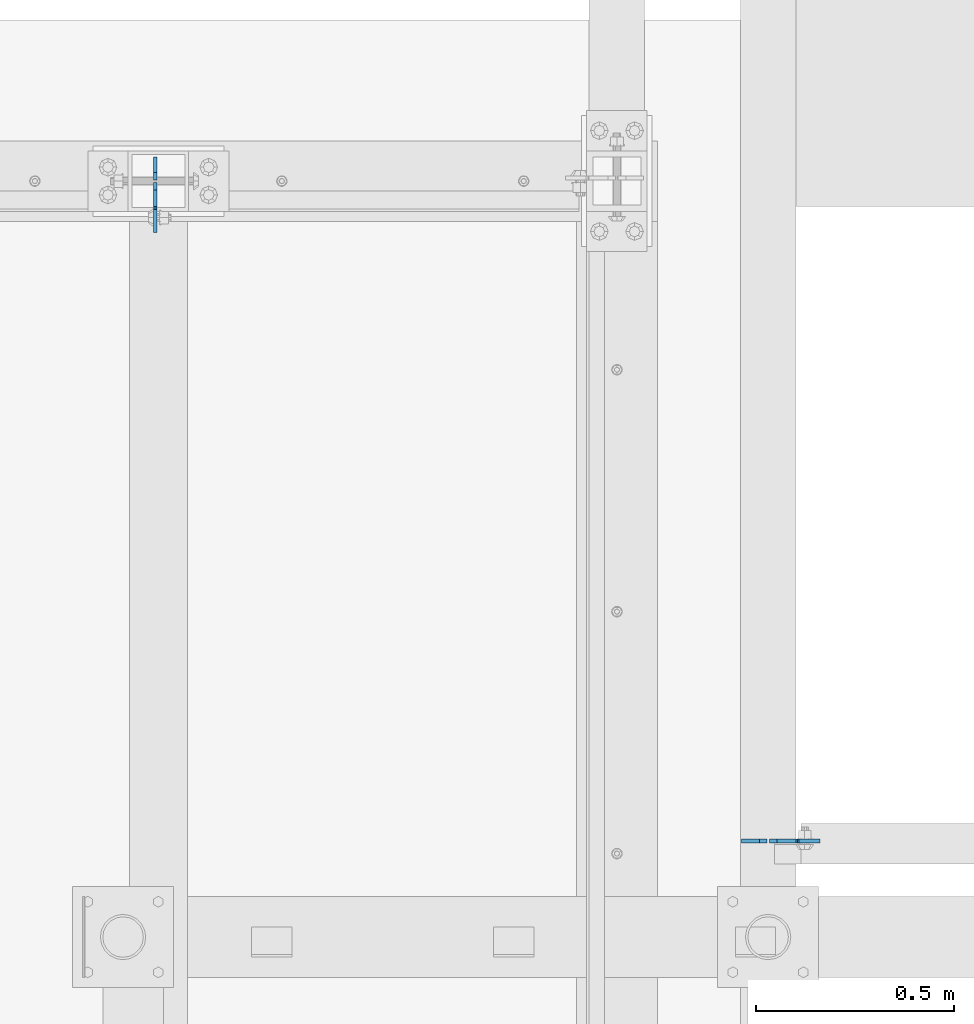
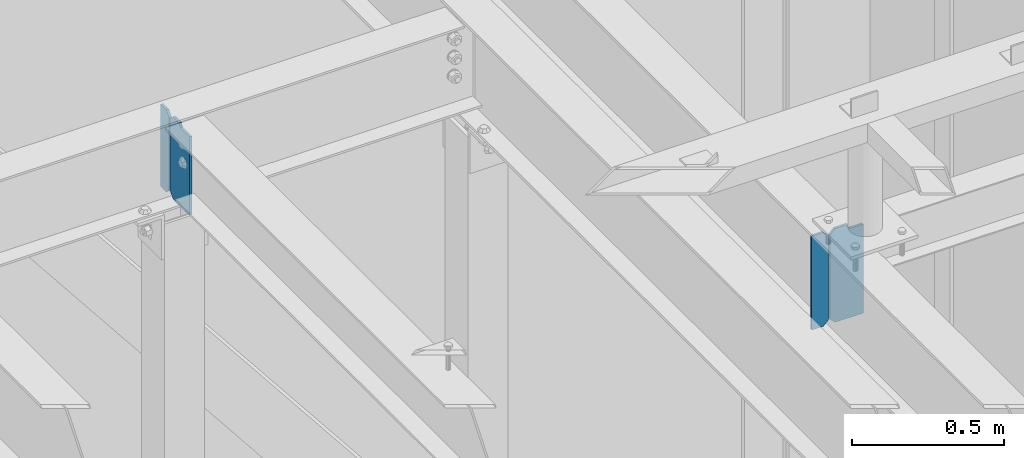
# One storey, part 1083 of 1179: 4 plates, 2 elements without a shape of their own.
"""IFC2X3 building model written with IfcOpenShell, lengths in millimetres."""

from ifc_helpers import new_model, si_unit, frame, origin_with_axes, place, context, subcontext, project, spatial, faceted_brep, material, type_object, element, aggregate, save


model = new_model("IFC2X3")

# Units and contexts
model_context = context("Model", 3, precision=1e-05, world=origin_with_axes())
body_context = subcontext(model_context, "Body", "Model", "MODEL_VIEW")
ifc_project = project(units=[si_unit("LENGTHUNIT", "METRE", prefix="MILLI"), si_unit("AREAUNIT", "SQUARE_METRE"), si_unit("VOLUMEUNIT", "CUBIC_METRE"), si_unit("MASSUNIT", "GRAM", prefix="KILO"), si_unit("TIMEUNIT", "SECOND"), si_unit("PLANEANGLEUNIT", "RADIAN"), si_unit("SOLIDANGLEUNIT", "STERADIAN"), si_unit("THERMODYNAMICTEMPERATUREUNIT", "DEGREE_CELSIUS"), si_unit("LUMINOUSINTENSITYUNIT", "LUMEN")], contexts=[model_context])

# Site, building, storey
site_placement = place(None, origin_with_axes())
site = spatial("IfcSite", under=ifc_project, at=site_placement, CompositionType="ELEMENT")
building_placement = place(site_placement, origin_with_axes())
building = spatial("IfcBuilding", under=site, at=building_placement, Name="Undefined", CompositionType="ELEMENT")
storey_placement = place(building_placement, origin_with_axes())
storey = spatial("IfcBuildingStorey", under=building, at=storey_placement, Name="Undefined", CompositionType="ELEMENT", Elevation=0.0)

# Assembly, plate
assembly_1_placement = place(storey_placement, origin_with_axes())
assembly_1 = element("IfcElementAssembly", 1, at=assembly_1_placement, inside=storey, Name="BEAM", AssemblyPlace="NOTDEFINED", PredefinedType="RIGID_FRAME")
ifc_material = material(Name="STEEL/A36")
plate_type_1 = type_object("IfcPlateType", PredefinedType="NOTDEFINED")
plate_1_placement = place(assembly_1_placement, frame((13022.2618838348, 39430.325, 12779.375), z_axis=(0.0, 0.0, 1.0), x_axis=(0.0, -1.0, 0.0)))
plate_1 = element("IfcPlate", 2, at=plate_1_placement, type_object=plate_type_1, material=ifc_material, Name="PLATE", context=body_context, shape_type="Brep", body=[
    faceted_brep([(60.3250000095268, -4.76250000000073, 330.200000000001), (60.3249999999971, -4.76250000000073, 327.024999809266), (60.3249999999971, 4.76250000000073, 327.024999809266), (60.3250000095268, 4.76250000000073, 330.200000000001), (61.2917299225883, -4.76250000000073, 322.164920291219), (61.2917299225883, 4.76250000000073, 322.164920291219), (64.0447438230622, -4.76250000000073, 318.044743823066), (64.0447438230622, 4.76250000000073, 318.044743823066), (68.1649202912158, -4.76250000000073, 315.291729922588), (68.1649202912158, 4.76250000000073, 315.291729922588), (73.0249998092622, -4.76250000000073, 314.325000000001), (73.0249998092622, 4.76250000000073, 314.325000000001), (127.0, -4.76250000000073, 314.325000000001), (127.0, 4.76250000000073, 314.325000000001), (0.0, -4.76250000000073, 311.150012969971), (19.0499992370605, -4.76250000000073, 330.200012207031), (19.0499992370605, 4.76250000000073, 330.200012207031), (0.0, 4.76250000000073, 311.150012969971), (0.0, -4.76250000000073, 19.0499992370605), (0.0, 4.76250000000073, 19.0499992370605), (19.0499992370605, -4.76250000000073, 0.0), (19.0499992370605, 4.76250000000073, 0.0), (127.0, -4.76250000000073, 0.0), (127.0, 4.76250000000073, 0.0)], [[[0, 1, 2, 3]], [[4, 5, 2, 1]], [[6, 7, 5, 4]], [[8, 9, 7, 6]], [[10, 11, 9, 8]], [[12, 13, 11, 10]], [[14, 15, 16, 17]], [[18, 14, 17, 19]], [[20, 18, 19, 21]], [[22, 20, 21, 23]], [[8, 6, 4, 1, 0, 15, 14, 18, 20, 22, 12, 10]], [[16, 15, 0, 3]], [[23, 21, 19, 17, 16, 3, 2, 5, 7, 9, 11, 13]], [[22, 23, 13, 12]]]),
])

assembly_2_placement = place(storey_placement, origin_with_axes())
assembly_2 = element("IfcElementAssembly", 3, at=assembly_2_placement, inside=storey, Name="BEAM", AssemblyPlace="NOTDEFINED", PredefinedType="RIGID_FRAME")
plate_2_placement = place(assembly_2_placement, frame((14570.075, 37770.5942499161, 12728.575), z_axis=(0.0, 0.0, 1.0), x_axis=(1.0, 0.0, 0.0)))
plate_2 = element("IfcPlate", 4, at=plate_2_placement, type_object=plate_type_1, material=ifc_material, Name="PLATE", context=body_context, shape_type="Brep", body=[
    faceted_brep([(66.6749998164378, -4.76249999999709, 377.825), (66.6749999434469, -4.76249999999709, 371.474999553748), (66.6749999434469, 4.76249999999709, 371.474999553748), (66.6749998164378, 4.76249999999709, 377.825), (67.641729938794, -4.76249999999709, 366.614920114053), (67.641729938794, 4.76249999999709, 366.614920114053), (70.394743855788, -4.76249999999709, 362.494743732281), (70.394743855788, 4.76249999999709, 362.494743732281), (74.5149202922948, -4.76249999999709, 359.741729897201), (74.5149202922948, 4.76249999999709, 359.741729897201), (79.3749997512095, -4.76249999999709, 358.774999998475), (79.3749997512095, 4.76249999999709, 358.774999998475), (127.000000004868, -4.76249999999709, 358.774999992755), (127.0, 4.76249999999709, 358.774999992755), (0.0, -4.76249999999709, 358.775000762939), (19.0499992370605, -4.76249999999709, 377.825), (19.0499992370605, 4.76249999999709, 377.825), (0.0, 4.76249999999709, 358.775000762939), (0.0, -4.76250000000073, 19.0499992370605), (0.0, 4.76250000000073, 19.0499992370605), (19.0499992370605, -4.76250000000073, 0.0), (19.0499992370605, 4.76250000000073, 0.0), (127.0, -4.76250000000073, 0.0), (127.0, 4.76250000000073, 0.0)], [[[0, 1, 2, 3]], [[4, 5, 2, 1]], [[6, 7, 5, 4]], [[8, 9, 7, 6]], [[10, 11, 9, 8]], [[12, 13, 11, 10]], [[14, 15, 16, 17]], [[18, 14, 17, 19]], [[20, 18, 19, 21]], [[22, 20, 21, 23]], [[8, 6, 4, 1, 0, 15, 14, 18, 20, 22, 12, 10]], [[16, 15, 0, 3]], [[23, 21, 19, 17, 16, 3, 2, 5, 7, 9, 11, 13]], [[22, 23, 13, 12]]]),
])

# Plate
plate_type_2 = type_object("IfcPlateType", PredefinedType="NOTDEFINED")
plate_3_placement = place(assembly_1_placement, frame((13022.2618838348, 39436.675, 12779.375), z_axis=(0.0, 0.0, 1.0), x_axis=(0.0, 1.0, 0.0)))
plate_3 = element("IfcPlate", 5, at=plate_3_placement, type_object=plate_type_2, material=ifc_material, Name="PLATE", context=body_context, shape_type="Brep", body=[
    faceted_brep([(0.0, -4.76250000000073, 19.0499992370605), (0.0, -4.76250000000073, 311.150012969971), (0.0, 4.76250000000073, 311.150012969971), (0.0, 4.76250000000073, 19.0499992370605), (19.0499992370605, -4.76250000000073, 330.200012207031), (19.0499992370605, 4.76250000000073, 330.200012207031), (57.1500015258789, -4.76250000000073, 330.200012207031), (57.1500015258789, 4.76250000000073, 330.200012207031), (57.1500015258789, -4.76250000000073, 0.0), (57.1500015258789, 4.76250000000073, 0.0), (19.0499992370605, -4.76250000000073, 0.0), (19.0499992370605, 4.76250000000073, 0.0)], [[[0, 1, 2, 3]], [[1, 4, 5, 2]], [[4, 6, 7, 5]], [[6, 8, 9, 7]], [[8, 10, 11, 9]], [[10, 0, 3, 11]], [[5, 7, 9, 11, 3, 2]], [[10, 8, 6, 4, 1, 0]]]),
])

aggregate(assembly_1, [plate_3, plate_1])

plate_type_3 = type_object("IfcPlateType", PredefinedType="NOTDEFINED")
plate_4_placement = place(assembly_2_placement, frame((14563.725, 37770.5942499161, 12728.575), z_axis=(0.0, 0.0, 1.0), x_axis=(-1.0, 0.0, 0.0)))
plate_4 = element("IfcPlate", 6, at=plate_4_placement, type_object=plate_type_3, material=ifc_material, Name="PLATE", context=body_context, shape_type="Brep", body=[
    faceted_brep([(0.0, -4.76250000000073, 19.0499992370605), (0.0, -4.76249999999709, 358.775000762939), (0.0, 4.76249999999709, 358.775000762939), (0.0, 4.76250000000073, 19.0499992370605), (19.0499992370605, -4.76249999999709, 377.825), (19.0499992370605, 4.76249999999709, 377.825), (63.5, -4.76250000000073, 377.825012207031), (63.5, 4.76250000000073, 377.825012207031), (63.5, -4.76250000000073, 0.0), (63.5, 4.76250000000073, 0.0), (19.0499992370605, -4.76250000000073, 0.0), (19.0499992370605, 4.76250000000073, 0.0)], [[[0, 1, 2, 3]], [[1, 4, 5, 2]], [[4, 6, 7, 5]], [[6, 8, 9, 7]], [[8, 10, 11, 9]], [[10, 0, 3, 11]], [[5, 7, 9, 11, 3, 2]], [[10, 8, 6, 4, 1, 0]]]),
])

aggregate(assembly_2, [plate_4, plate_2])

save(model, "model.ifc")
